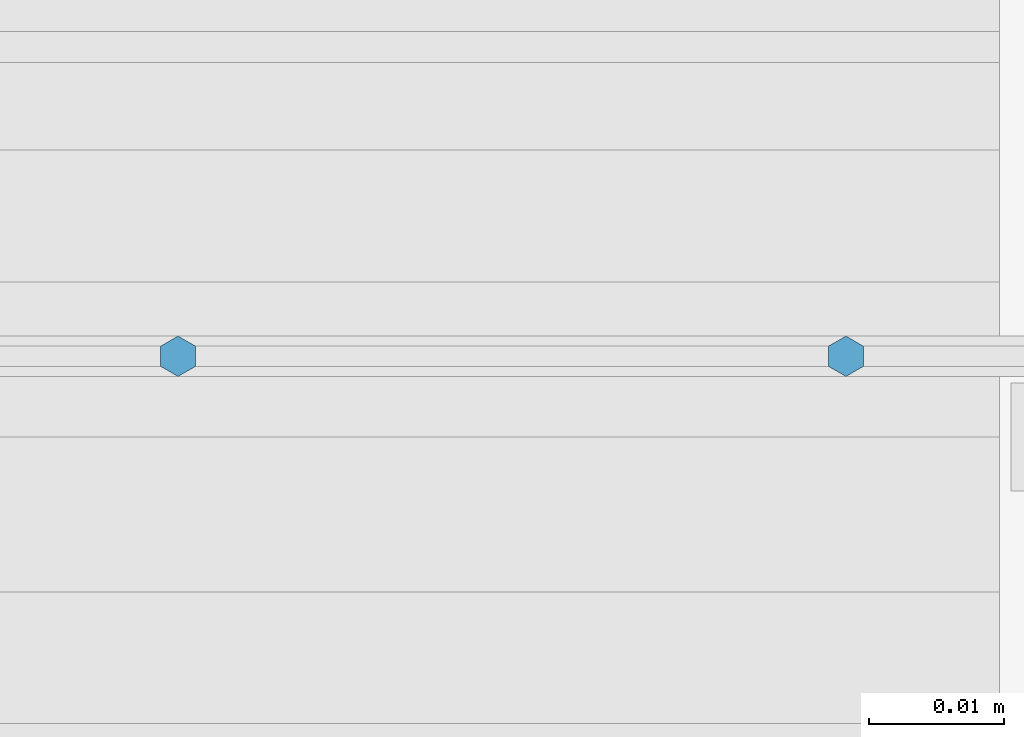
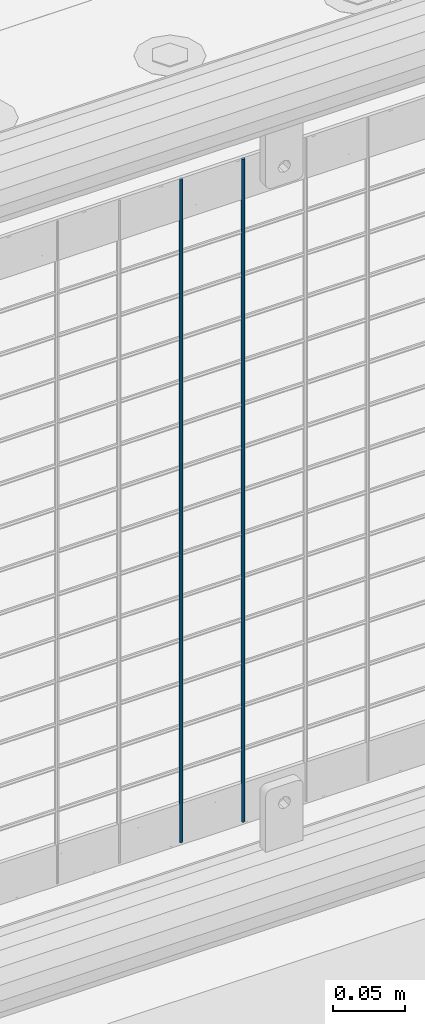
# One storey, part 73 of 208: 2 columns.
"""IFC2X3 building model written with IfcOpenShell, lengths in millimetres."""

from ifc_helpers import new_model, si_unit, frame, origin_with_axes, place, context, subcontext, project, spatial, faceted_brep, material, type_object, element, save


model = new_model("IFC2X3")

# Units and contexts
model_context = context("Model", 3, precision=1e-05, world=origin_with_axes())
body_context = subcontext(model_context, "Body", "Model", "MODEL_VIEW")
ifc_project = project(units=[si_unit("LENGTHUNIT", "METRE", prefix="MILLI"), si_unit("AREAUNIT", "SQUARE_METRE"), si_unit("VOLUMEUNIT", "CUBIC_METRE"), si_unit("MASSUNIT", "GRAM", prefix="KILO"), si_unit("TIMEUNIT", "SECOND"), si_unit("PLANEANGLEUNIT", "RADIAN"), si_unit("SOLIDANGLEUNIT", "STERADIAN"), si_unit("THERMODYNAMICTEMPERATUREUNIT", "DEGREE_CELSIUS"), si_unit("LUMINOUSINTENSITYUNIT", "LUMEN")], contexts=[model_context])

# Site, building, storey
site_placement = place(None, origin_with_axes())
site = spatial("IfcSite", under=ifc_project, at=site_placement, CompositionType="ELEMENT")
building_placement = place(site_placement, origin_with_axes())
building = spatial("IfcBuilding", under=site, at=building_placement, Name="Standard", CompositionType="ELEMENT")
storey_placement = place(building_placement, origin_with_axes())
storey = spatial("IfcBuildingStorey", under=building, at=storey_placement, Name="Undefined", CompositionType="ELEMENT", Elevation=0.0)

# Columns
ifc_material = material(Name="Misc_Undefined")
column_type = type_object("IfcColumnType", Name="D3", PredefinedType="NOTDEFINED")
for number, where, z_axis, x_axis in (
    (1, (-33401.415, 4670.5, 353.020000000003), (-1.0, 0.0, 0.0), (0.0, 0.0, 1.0)),
    (2, (-33451.07, 4670.5, 353.020000000003), (-1.0, 0.0, 0.0), (0.0, 0.0, 1.0)),
):
    element("IfcColumn", number, at=place(storey_placement, frame(where, z_axis=z_axis, x_axis=x_axis)), inside=storey, type_object=column_type, material=ifc_material, ObjectType="D3", context=body_context, shape_type="Brep", body=[
        faceted_brep([(0.0, -1.49999999999909, 3.63797880709171e-12), (-7.27595761418343e-12, -0.749999999999091, -1.29903810567669), (560.0, -0.75, -1.29903810567703), (560.0, -1.5, 0.0), (-3.63797880709171e-12, 0.750000000000909, -1.29903810567669), (560.0, 0.75, -1.29903810567703), (0.0, 1.50000000000182, 3.63797880709171e-12), (560.0, 1.5, 0.0), (-3.63797880709171e-12, 0.750000000000909, 1.29903810567669), (560.0, 0.75, 1.29903810567703), (-7.27595761418343e-12, -0.749999999999091, 1.29903810567669), (560.0, -0.75, 1.29903810567703)], [[[0, 1, 2, 3]], [[1, 4, 5, 2]], [[4, 6, 7, 5]], [[6, 8, 9, 7]], [[8, 10, 11, 9]], [[10, 0, 3, 11]], [[5, 7, 9, 11, 3, 2]], [[10, 8, 6, 4, 1, 0]]]),
    ])

save(model, "model.ifc")
